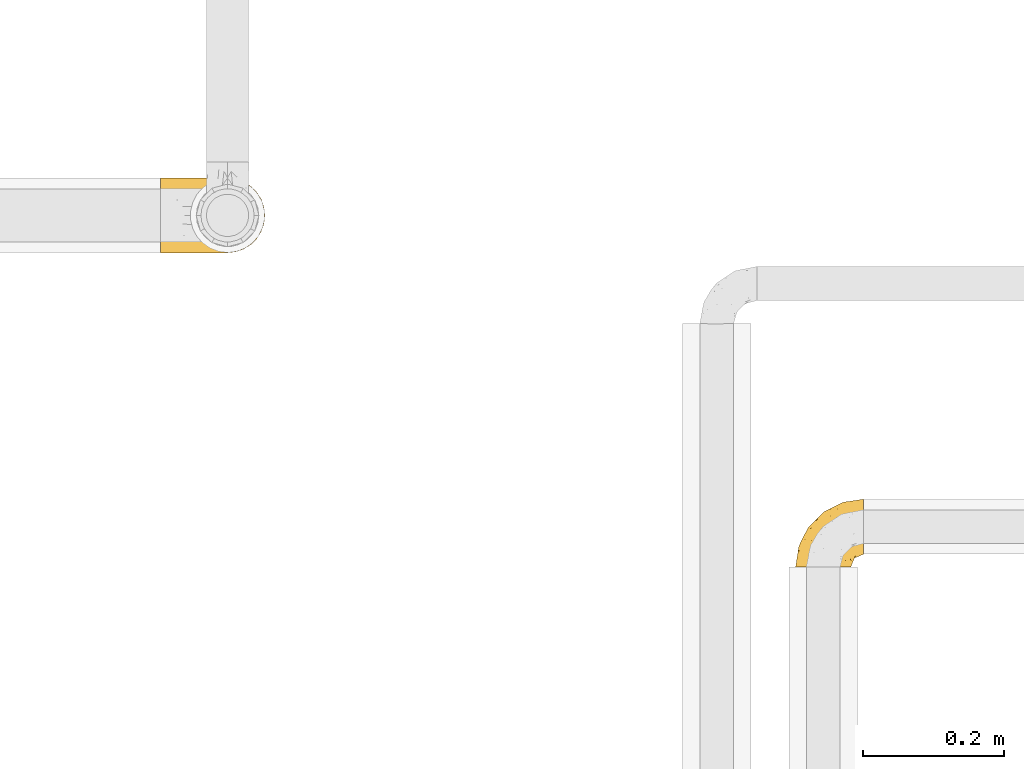
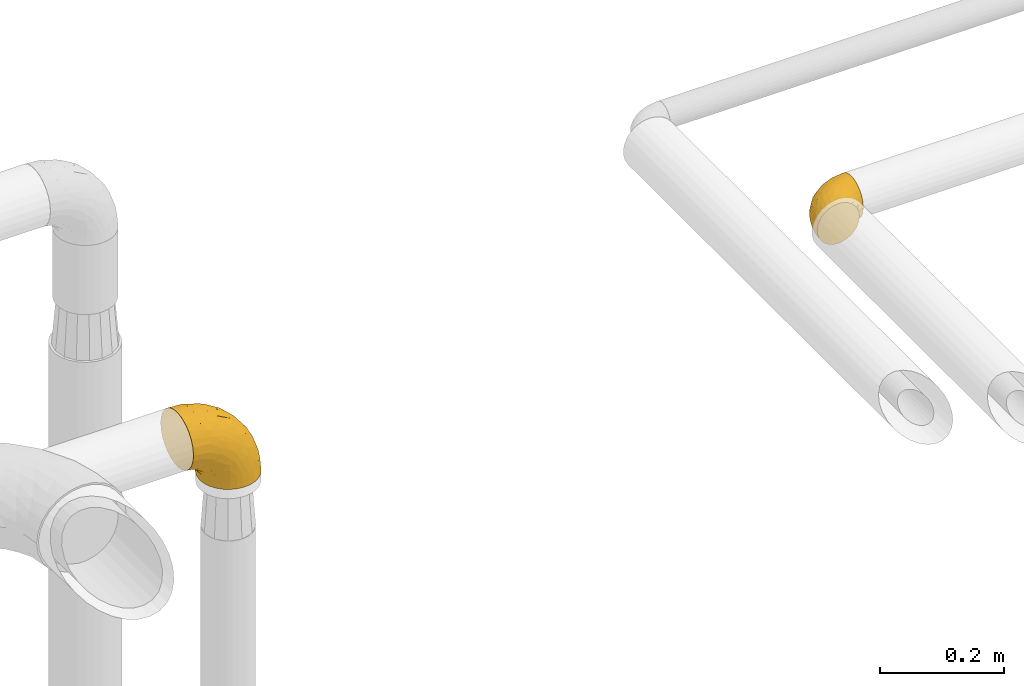
# One storey, part 137 of 827: 2 coverings.
"""IFC2X3 building model written with IfcOpenShell, lengths in millimetres."""

from ifc_helpers import new_model, entity, si_unit, converted_unit, derived_unit, direction, frame, origin, place, context, subcontext, project, spatial, faceted_brep, element, save


model = new_model("IFC2X3")

# Units and contexts
model_context = context("Model", 3, precision=0.01, world=origin(), true_north=direction((6.12303176911189e-17, 1.0)))
body_context = subcontext(model_context, "Body", "Model", "MODEL_VIEW")
ifc_project = project(units=[si_unit("LENGTHUNIT", "METRE", prefix="MILLI"), si_unit("AREAUNIT", "SQUARE_METRE"), si_unit("VOLUMEUNIT", "CUBIC_METRE"), converted_unit("PLANEANGLEUNIT", "DEGREE", entity("IfcRatioMeasure", 0.0174532925199433), si_unit("PLANEANGLEUNIT", "RADIAN"), dimensions=[0, 0, 0, 0, 0, 0, 0]), si_unit("MASSUNIT", "GRAM", prefix="KILO"), derived_unit("MASSDENSITYUNIT", [(si_unit("MASSUNIT", "GRAM", prefix="KILO"), 1), (si_unit("LENGTHUNIT", "METRE"), -3)]), derived_unit("MOMENTOFINERTIAUNIT", [(si_unit("LENGTHUNIT", "METRE"), 4)]), si_unit("TIMEUNIT", "SECOND"), si_unit("FREQUENCYUNIT", "HERTZ"), si_unit("THERMODYNAMICTEMPERATUREUNIT", "DEGREE_CELSIUS"), derived_unit("THERMALTRANSMITTANCEUNIT", [(si_unit("MASSUNIT", "GRAM", prefix="KILO"), 1), (si_unit("THERMODYNAMICTEMPERATUREUNIT", "KELVIN"), -1), (si_unit("TIMEUNIT", "SECOND"), -3)]), derived_unit("VOLUMETRICFLOWRATEUNIT", [(si_unit("LENGTHUNIT", "METRE"), 3), (si_unit("TIMEUNIT", "SECOND"), -1)]), derived_unit("MASSFLOWRATEUNIT", [(si_unit("MASSUNIT", "GRAM", prefix="KILO"), 1), (si_unit("TIMEUNIT", "SECOND"), -1)]), derived_unit("ROTATIONALFREQUENCYUNIT", [(si_unit("TIMEUNIT", "SECOND"), -1)]), si_unit("ELECTRICCURRENTUNIT", "AMPERE"), si_unit("ELECTRICVOLTAGEUNIT", "VOLT"), si_unit("POWERUNIT", "WATT"), si_unit("FORCEUNIT", "NEWTON", prefix="KILO"), si_unit("ILLUMINANCEUNIT", "LUX"), si_unit("LUMINOUSFLUXUNIT", "LUMEN"), si_unit("LUMINOUSINTENSITYUNIT", "CANDELA"), derived_unit("USERDEFINED", [(si_unit("MASSUNIT", "GRAM", prefix="KILO"), -1), (si_unit("LENGTHUNIT", "METRE"), -2), (si_unit("TIMEUNIT", "SECOND"), 3), (si_unit("LUMINOUSFLUXUNIT", "LUMEN"), 1)]), derived_unit("LINEARVELOCITYUNIT", [(si_unit("LENGTHUNIT", "METRE"), 1), (si_unit("TIMEUNIT", "SECOND"), -1)]), si_unit("PRESSUREUNIT", "PASCAL"), derived_unit("USERDEFINED", [(si_unit("LENGTHUNIT", "METRE"), -2), (si_unit("MASSUNIT", "GRAM", prefix="KILO"), 1), (si_unit("TIMEUNIT", "SECOND"), -2)]), derived_unit("LINEARFORCEUNIT", [(si_unit("MASSUNIT", "GRAM", prefix="KILO"), 1), (si_unit("LENGTHUNIT", "METRE"), 1), (si_unit("TIMEUNIT", "SECOND"), -2), (si_unit("LENGTHUNIT", "METRE"), -1)]), derived_unit("PLANARFORCEUNIT", [(si_unit("MASSUNIT", "GRAM", prefix="KILO"), 1), (si_unit("LENGTHUNIT", "METRE"), 1), (si_unit("TIMEUNIT", "SECOND"), -2), (si_unit("LENGTHUNIT", "METRE"), -2)])], contexts=[model_context])

# Site, building, storey
site_placement = place(None, origin())
site = spatial("IfcSite", under=ifc_project, at=site_placement, CompositionType="ELEMENT")
building_placement = place(site_placement, origin())
building = spatial("IfcBuilding", under=site, at=building_placement, CompositionType="ELEMENT")
storey_placement = place(building_placement, frame((0.0, 0.0, 28200.0)))
storey = spatial("IfcBuildingStorey", under=building, at=storey_placement, Name="08", CompositionType="ELEMENT", Elevation=28200.0)

# Coverings
covering_1_placement = place(storey_placement, frame((23473.64, 14446.95, 2955.74)))
element("IfcCovering", 1, at=covering_1_placement, inside=storey, Name=":ADSK_", ObjectType=":ADSK_", PredefinedType="INSULATION", context=body_context, shape_type="Brep", body=[
    faceted_brep([(31.97, 1.6, 78.9), (23.7, 1.6, 75.99), (16.29, 1.61, 71.31), (10.1, 1.62, 65.1), (5.45, 1.64, 57.68), (2.56, 1.65, 49.4), (1.6, 1.67, 40.69), (2.59, 1.69, 31.97), (5.5, 1.7, 23.7), (10.18, 1.72, 16.29), (16.39, 1.73, 10.1), (23.82, 1.74, 5.45), (32.09, 1.74, 2.56), (40.8, 1.75, 1.6), (44.0, 1.75, 1.96), (49.52, 1.74, 2.59), (53.65, 1.74, 4.05), (57.79, 1.74, 5.5), (65.2, 1.73, 10.18), (71.39, 1.72, 16.39), (76.05, 1.7, 23.82), (78.93, 1.69, 32.09), (79.9, 1.67, 40.8), (78.9, 1.65, 49.52), (75.99, 1.64, 57.79), (71.31, 1.62, 65.2), (65.1, 1.61, 71.39), (57.68, 1.6, 76.05), (49.4, 1.6, 78.93), (43.89, 1.6, 79.54), (40.69, 1.6, 79.9), (97.79, 31.04, 13.2), (97.8, 39.16, 6.99), (97.81, 48.61, 3.1), (97.81, 52.33, 2.62), (97.81, 55.54, 2.2), (97.81, 58.75, 1.79), (97.81, 68.88, 3.14), (97.8, 78.31, 7.07), (97.8, 86.41, 13.31), (97.78, 92.61, 21.43), (97.77, 96.51, 30.88), (97.76, 97.82, 41.01), (97.74, 96.47, 51.14), (97.73, 92.54, 60.58), (97.72, 86.3, 68.67), (97.71, 78.18, 74.88), (97.7, 68.73, 78.77), (97.7, 58.6, 80.09), (97.7, 52.18, 79.23), (97.7, 48.46, 78.73), (97.7, 39.03, 74.8), (97.71, 30.93, 68.57), (97.72, 24.73, 60.45), (97.73, 20.84, 51.0), (97.75, 19.52, 40.86), (97.76, 20.87, 30.73), (97.78, 24.8, 21.3), (30.6, 68.83, 40.86), (19.96, 58.19, 40.82), (31.38, 68.0, 54.11), (41.24, 79.46, 40.9), (68.04, 93.12, 40.96), (73.86, 94.19, 47.71), (78.5, 94.77, 40.98), (51.05, 83.98, 51.69), (61.03, 83.78, 62.05), (74.95, 92.51, 54.66), (80.62, 88.92, 63.59), (35.89, 18.55, 79.27), (55.4, 59.48, 77.17), (78.14, 73.44, 75.98), (58.04, 70.78, 72.77), (78.35, 64.34, 79.1), (74.61, 81.22, 70.32), (14.57, 24.8, 66.71), (20.0, 18.98, 72.71), (24.21, 39.71, 70.26), (43.75, 39.99, 78.88), (45.03, 23.41, 79.94), (48.12, 28.03, 79.96), (51.21, 32.66, 79.97), (54.3, 37.28, 79.98), (57.39, 41.9, 80.0), (40.2, 52.72, 74.54), (6.2, 24.56, 52.46), (61.18, 53.68, 79.46), (62.01, 44.99, 80.01), (66.63, 48.08, 80.02), (71.26, 51.17, 80.03), (75.88, 54.26, 80.05), (13.07, 45.37, 48.98), (14.96, 41.23, 58.82), (8.47, 18.58, 60.42), (4.65, 20.93, 40.73), (36.64, 67.55, 62.14), (22.94, 55.87, 57.61), (41.4, 5.17, 79.9), (42.11, 8.74, 79.91), (43.53, 15.88, 79.93), (25.21, 52.22, 64.2), (31.2, 35.24, 75.81), (26.91, 17.81, 76.66), (37.97, 60.94, 69.03), (50.62, 73.92, 66.88), (54.64, 86.29, 40.93), (6.3, 31.39, 40.75), (83.41, 55.76, 80.06), (86.98, 56.47, 80.07), (90.55, 57.18, 80.07), (13.13, 44.79, 40.79), (91.76, 26.32, 63.98), (87.16, 29.77, 69.27), (87.45, 47.68, 78.81), (89.75, 35.47, 73.12), (88.41, 41.53, 76.62), (81.72, 40.22, 76.95), (79.76, 47.1, 79.19), (73.79, 44.48, 79.22), (91.82, 20.02, 51.39), (86.6, 17.33, 51.13), (85.12, 14.29, 40.83), (91.15, 16.79, 40.85), (80.83, 10.19, 50.0), (78.93, 13.32, 58.61), (71.34, 17.58, 69.93), (76.77, 17.74, 65.28), (74.25, 23.17, 70.84), (48.24, 8.48, 79.28), (49.92, 13.45, 79.15), (92.83, 22.88, 58.0), (77.52, 7.07, 55.99), (62.0, 29.24, 78.14), (70.81, 29.52, 75.48), (65.47, 33.68, 78.26), (80.67, 23.37, 66.73), (77.93, 30.52, 73.25), (66.09, 7.99, 71.12), (56.95, 22.98, 78.39), (64.52, 16.18, 74.0), (56.48, 13.36, 77.3), (51.01, 19.39, 79.31), (81.82, 18.37, 60.4), (82.63, 8.27, 40.82), (72.49, 10.85, 65.78), (67.65, 23.5, 74.59), (86.41, 21.97, 60.73), (82.4, 34.49, 74.08), (75.93, 38.65, 77.42), (70.34, 36.65, 77.94), (92.88, 22.95, 23.72), (89.02, 25.61, 17.68), (41.51, 5.32, 1.6), (42.22, 8.89, 1.61), (43.64, 16.03, 1.63), (80.85, 10.23, 31.64), (78.99, 13.39, 23.05), (77.57, 7.13, 25.63), (72.58, 10.95, 15.85), (83.52, 55.91, 1.76), (90.67, 57.33, 1.77), (94.24, 58.04, 1.78), (87.24, 29.88, 12.46), (82.65, 34.64, 7.69), (89.39, 34.98, 8.99), (80.8, 46.68, 2.78), (81.83, 40.36, 4.8), (74.1, 44.99, 2.49), (75.99, 54.41, 1.75), (87.56, 47.83, 3.0), (51.13, 19.54, 2.28), (48.23, 28.18, 1.66), (57.08, 23.11, 3.24), (74.35, 23.29, 10.83), (80.64, 23.03, 15.28), (77.12, 18.03, 16.51), (91.85, 20.06, 30.32), (79.24, 28.77, 10.08), (86.63, 17.37, 30.56), (66.19, 8.11, 10.47), (71.89, 17.58, 12.13), (56.6, 13.5, 4.29), (64.63, 16.31, 7.63), (62.11, 29.38, 3.52), (50.04, 13.59, 2.41), (45.14, 23.56, 1.64), (70.45, 36.79, 3.77), (76.42, 38.26, 4.58), (67.76, 23.65, 7.06), (70.96, 29.66, 6.22), (89.39, 41.05, 5.53), (82.07, 18.33, 21.67), (51.32, 32.81, 1.67), (86.47, 22.05, 20.97), (65.61, 33.78, 3.45), (62.12, 45.14, 1.71), (57.5, 42.05, 1.7), (54.41, 37.43, 1.68), (71.37, 51.32, 1.74), (66.75, 48.23, 1.72), (61.29, 53.83, 2.29), (74.7, 81.33, 11.57), (78.25, 73.58, 5.89), (58.12, 70.9, 9.03), (38.05, 61.04, 12.68), (40.3, 52.84, 7.14), (24.31, 39.82, 11.32), (25.28, 52.3, 17.44), (43.87, 40.13, 2.77), (78.46, 64.49, 2.74), (73.88, 94.22, 34.23), (74.99, 92.57, 27.29), (55.5, 59.61, 4.58), (31.31, 35.37, 5.78), (80.68, 89.01, 18.35), (61.08, 83.86, 19.82), (31.41, 68.05, 27.61), (36.71, 67.64, 19.59), (36.0, 18.7, 2.27), (6.24, 24.61, 29.01), (14.65, 24.9, 14.79), (13.1, 45.41, 32.59), (20.11, 19.1, 8.78), (51.08, 84.02, 30.15), (23.0, 55.93, 24.03), (15.01, 41.3, 22.74), (8.53, 18.66, 21.03), (50.68, 74.0, 14.91), (27.02, 17.94, 4.85)], [[[0, 1, 2, 3, 4, 5, 6, 7, 8, 9, 10, 11, 12, 13, 14, 15, 16, 17, 18, 19, 20, 21, 22, 23, 24, 25, 26, 27, 28, 29, 30]], [[31, 32, 33, 34, 35, 36, 37, 38, 39, 40, 41, 42, 43, 44, 45, 46, 47, 48, 49, 50, 51, 52, 53, 54, 55, 56, 57]], [[58, 59, 60, 61]], [[62, 63, 64]], [[65, 66, 67]], [[67, 66, 68]], [[69, 0, 30]], [[70, 71, 72]], [[44, 43, 67]], [[47, 71, 73]], [[45, 74, 46]], [[68, 45, 44]], [[75, 76, 77]], [[76, 2, 1]], [[78, 79, 80, 81, 82, 83]], [[48, 47, 73]], [[70, 72, 84]], [[4, 85, 5]], [[86, 83, 87, 88, 89, 90]], [[91, 85, 92]], [[76, 75, 2]], [[71, 46, 74]], [[85, 4, 93]], [[45, 68, 74]], [[4, 3, 93]], [[85, 94, 5]], [[86, 78, 83]], [[60, 95, 65]], [[96, 95, 60]], [[75, 3, 2]], [[69, 30, 97, 98, 99, 79]], [[75, 77, 100]], [[43, 64, 63]], [[101, 102, 69]], [[101, 76, 102]], [[46, 71, 47]], [[95, 103, 104]], [[92, 85, 93]], [[63, 105, 65]], [[92, 75, 100]], [[91, 106, 85]], [[84, 78, 70]], [[67, 68, 44]], [[65, 67, 63]], [[65, 61, 60]], [[3, 75, 93]], [[92, 93, 75]], [[102, 76, 1]], [[77, 76, 101]], [[84, 77, 101]], [[77, 103, 100]], [[72, 71, 74]], [[70, 86, 73]], [[104, 74, 66]], [[84, 72, 103]], [[70, 73, 71]], [[73, 90, 107, 108, 109, 48]], [[79, 78, 69]], [[101, 69, 78]], [[91, 92, 96]], [[91, 59, 110, 106]], [[1, 0, 102]], [[69, 102, 0]], [[94, 85, 106]], [[94, 6, 5]], [[74, 68, 66]], [[43, 42, 64]], [[43, 63, 67]], [[73, 86, 90]], [[78, 86, 70]], [[95, 100, 103]], [[96, 92, 100]], [[104, 103, 72]], [[65, 95, 66]], [[74, 104, 72]], [[66, 95, 104]], [[95, 96, 100]], [[91, 96, 60]], [[77, 84, 103]], [[78, 84, 101]], [[60, 59, 91]], [[105, 63, 62]], [[105, 61, 65]], [[111, 52, 112]], [[107, 90, 113]], [[114, 115, 116]], [[50, 107, 113]], [[117, 118, 116]], [[54, 119, 55]], [[97, 30, 29, 28, 98]], [[113, 115, 51]], [[120, 121, 122]], [[123, 120, 124]], [[125, 126, 127]], [[128, 27, 129]], [[130, 54, 53]], [[24, 23, 131]], [[132, 133, 134]], [[135, 112, 136]], [[137, 26, 25]], [[121, 120, 123]], [[138, 139, 132]], [[129, 140, 141]], [[135, 126, 142]], [[26, 140, 27]], [[26, 137, 140]], [[49, 48, 109, 108, 107, 50]], [[22, 143, 121, 123]], [[24, 131, 144]], [[25, 24, 144]], [[128, 98, 28]], [[125, 127, 145]], [[146, 130, 111]], [[137, 144, 139]], [[139, 138, 140]], [[116, 147, 114]], [[123, 124, 131]], [[116, 118, 148]], [[134, 83, 82]], [[129, 79, 99]], [[54, 130, 119]], [[141, 79, 129]], [[122, 55, 119]], [[120, 146, 142]], [[117, 113, 90]], [[50, 113, 51]], [[127, 133, 145]], [[147, 136, 112]], [[136, 133, 127]], [[23, 22, 123]], [[118, 117, 89]], [[149, 87, 134]], [[144, 131, 124]], [[23, 123, 131]], [[128, 129, 99]], [[27, 140, 129]], [[144, 137, 25]], [[140, 137, 139]], [[81, 138, 132]], [[138, 80, 141]], [[89, 88, 87, 118]], [[115, 117, 116]], [[140, 138, 141]], [[148, 118, 149]], [[136, 148, 149]], [[147, 116, 148]], [[133, 136, 149]], [[127, 126, 135]], [[136, 147, 148]], [[114, 112, 52]], [[112, 114, 147]], [[51, 114, 52]], [[51, 115, 114]], [[117, 115, 113]], [[117, 90, 89]], [[134, 133, 149]], [[145, 133, 132]], [[132, 139, 145]], [[125, 139, 144]], [[139, 125, 145]], [[126, 144, 124]], [[144, 126, 125]], [[142, 126, 124]], [[120, 142, 124]], [[142, 146, 135]], [[112, 135, 146]], [[136, 127, 135]], [[118, 87, 149]], [[82, 81, 132]], [[111, 130, 53]], [[119, 146, 120]], [[146, 119, 130]], [[122, 119, 120]], [[52, 111, 53]], [[146, 111, 112]], [[134, 82, 132]], [[83, 134, 87]], [[98, 128, 99]], [[80, 138, 81]], [[80, 79, 141]], [[27, 128, 28]], [[150, 151, 57]], [[14, 13, 152, 153, 154, 15]], [[121, 143, 22, 155]], [[150, 57, 56]], [[156, 157, 158]], [[35, 34, 33, 159, 160, 161, 36]], [[162, 31, 57]], [[163, 164, 162]], [[165, 166, 167]], [[155, 22, 21]], [[168, 159, 169]], [[170, 171, 172]], [[173, 174, 175]], [[55, 122, 176]], [[177, 174, 173]], [[21, 157, 155]], [[178, 121, 155]], [[169, 33, 32]], [[19, 18, 179]], [[20, 19, 158]], [[158, 180, 175]], [[181, 182, 179]], [[172, 183, 182]], [[122, 121, 178]], [[181, 18, 17]], [[184, 185, 170]], [[16, 154, 184]], [[186, 187, 177]], [[187, 186, 167]], [[179, 158, 19]], [[20, 157, 21]], [[175, 180, 173]], [[188, 189, 173]], [[164, 166, 190]], [[185, 184, 154]], [[181, 172, 182]], [[156, 191, 178]], [[192, 183, 172]], [[178, 176, 122]], [[193, 150, 176]], [[33, 169, 159]], [[190, 169, 32]], [[189, 194, 186]], [[180, 188, 173]], [[167, 166, 187]], [[166, 164, 163]], [[195, 194, 196]], [[158, 157, 20]], [[155, 157, 156]], [[178, 155, 156]], [[181, 17, 184]], [[16, 15, 154]], [[181, 179, 18]], [[158, 179, 182]], [[170, 181, 184]], [[196, 194, 197]], [[31, 190, 32]], [[165, 190, 166]], [[190, 31, 164]], [[31, 162, 164]], [[177, 163, 162]], [[187, 166, 163]], [[151, 174, 177]], [[177, 173, 189]], [[177, 187, 163]], [[195, 167, 186]], [[165, 198, 168]], [[165, 168, 169]], [[167, 198, 165]], [[190, 165, 169]], [[167, 195, 199, 198]], [[151, 177, 162]], [[175, 191, 156]], [[191, 174, 193]], [[158, 175, 156]], [[174, 191, 175]], [[178, 191, 193]], [[158, 182, 180]], [[188, 182, 183]], [[182, 188, 180]], [[183, 194, 189]], [[183, 189, 188]], [[177, 189, 186]], [[194, 183, 197]], [[176, 150, 56]], [[151, 150, 193]], [[176, 56, 55]], [[193, 176, 178]], [[174, 151, 193]], [[57, 151, 162]], [[183, 192, 197]], [[194, 195, 186]], [[171, 192, 172]], [[172, 181, 170]], [[170, 185, 171]], [[184, 17, 16]], [[200, 168, 198, 199, 195, 196]], [[201, 202, 203]], [[204, 203, 205]], [[204, 206, 207]], [[208, 196, 197, 192, 171, 185]], [[209, 36, 161, 160, 159, 168]], [[202, 38, 37]], [[201, 38, 202]], [[210, 41, 211]], [[200, 208, 212]], [[205, 208, 213]], [[214, 211, 40]], [[40, 211, 41]], [[214, 201, 215]], [[58, 61, 216, 59]], [[201, 39, 38]], [[207, 217, 204]], [[213, 208, 218]], [[218, 185, 154, 153, 152, 13]], [[13, 12, 218]], [[8, 7, 219]], [[9, 220, 10]], [[221, 106, 110, 59]], [[219, 7, 94]], [[220, 222, 10]], [[223, 211, 215]], [[221, 216, 224]], [[225, 219, 221]], [[9, 8, 226]], [[213, 222, 206]], [[226, 8, 219]], [[106, 219, 94]], [[212, 202, 209]], [[201, 203, 227]], [[226, 225, 220]], [[207, 206, 220]], [[214, 40, 39]], [[10, 222, 11]], [[11, 222, 228]], [[41, 210, 64]], [[223, 105, 210]], [[223, 215, 217]], [[105, 62, 210]], [[206, 222, 220]], [[228, 222, 213]], [[207, 220, 225]], [[205, 206, 204]], [[225, 226, 219]], [[220, 9, 226]], [[209, 202, 37]], [[203, 202, 212]], [[205, 203, 212]], [[204, 217, 227]], [[36, 209, 37]], [[209, 168, 200]], [[218, 12, 228]], [[208, 185, 218]], [[106, 221, 219]], [[221, 59, 216]], [[218, 228, 213]], [[12, 11, 228]], [[7, 6, 94]], [[201, 214, 39]], [[211, 214, 215]], [[64, 210, 62]], [[64, 42, 41]], [[223, 210, 211]], [[208, 200, 196]], [[209, 200, 212]], [[225, 224, 207]], [[207, 224, 217]], [[223, 217, 216]], [[204, 227, 203]], [[217, 215, 227]], [[201, 227, 215]], [[221, 224, 225]], [[217, 224, 216]], [[208, 205, 212]], [[206, 205, 213]], [[216, 61, 223]], [[223, 61, 105]]]),
])
covering_2_placement = place(storey_placement, frame((22572.86, 14892.6, 2503.4)))
element("IfcCovering", 2, at=covering_2_placement, inside=storey, Name=":ADSK_", ObjectType=":ADSK_", PredefinedType="INSULATION", context=body_context, shape_type="Brep", body=[
    faceted_brep([(148.32, 66.44, 1.6), (149.65, 54.65, 1.6), (148.31, 42.84, 1.6), (144.39, 31.62, 1.6), (138.06, 21.56, 1.6), (129.66, 13.16, 1.6), (119.6, 6.84, 1.6), (108.39, 2.92, 1.6), (96.6, 1.6, 1.6), (84.79, 2.93, 1.6), (73.57, 6.85, 1.6), (63.51, 13.18, 1.6), (55.11, 21.58, 1.6), (48.79, 31.64, 1.6), (44.87, 42.85, 1.6), (43.55, 54.65, 1.6), (44.88, 66.46, 1.6), (48.8, 77.67, 1.6), (55.13, 87.73, 1.6), (63.53, 96.13, 1.6), (73.59, 102.45, 1.6), (84.8, 106.37, 1.6), (96.6, 107.7, 1.6), (108.41, 106.36, 1.6), (119.62, 102.44, 1.6), (129.68, 96.11, 1.6), (138.08, 87.71, 1.6), (144.4, 77.65, 1.6), (1.6, 40.91, 45.35), (1.6, 28.12, 50.65), (1.6, 17.13, 59.08), (1.6, 8.7, 70.07), (1.6, 3.4, 82.86), (1.6, 1.6, 96.6), (1.6, 3.4, 110.33), (1.6, 8.7, 123.12), (1.6, 17.13, 134.11), (1.6, 28.12, 142.54), (1.6, 40.91, 147.84), (1.6, 54.65, 149.65), (1.6, 68.38, 147.84), (1.6, 81.17, 142.54), (1.6, 92.16, 134.11), (1.6, 100.59, 123.12), (1.6, 105.89, 110.33), (1.6, 107.7, 96.6), (1.6, 105.89, 82.86), (1.6, 100.59, 70.07), (1.6, 92.16, 59.08), (1.6, 81.17, 50.65), (1.6, 68.38, 45.35), (1.6, 54.65, 43.55), (27.97, 85.53, 137.19), (37.09, 73.42, 141.79), (58.27, 83.77, 128.89), (27.13, 64.22, 146.54), (39.91, 54.65, 144.6), (109.11, 96.72, 69.77), (94.41, 93.36, 94.41), (110.94, 84.47, 87.22), (89.69, 71.37, 117.2), (75.62, 54.65, 129.81), (106.28, 54.65, 106.28), (60.12, 103.47, 101.45), (41.41, 100.91, 115.81), (63.22, 99.1, 109.14), (32.05, 105.43, 107.65), (52.13, 106.79, 93.36), (123.27, 89.81, 59.44), (129.32, 79.59, 63.23), (138.3, 81.29, 35.59), (62.95, 74.01, 132.3), (55.89, 64.14, 138.41), (37.4, 94.75, 126.28), (144.6, 54.65, 39.91), (142.66, 70.74, 37.44), (117.85, 68.3, 90.35), (134.01, 66.05, 65.0), (89.25, 100.73, 85.4), (103.34, 106.78, 26.66), (113.52, 103.6, 29.88), (57.43, 107.7, 78.45), (44.19, 107.7, 85.2), (30.95, 107.7, 91.95), (77.98, 106.07, 77.98), (132.66, 90.59, 29.55), (121.52, 97.43, 41.42), (86.93, 84.51, 111.13), (68.4, 93.3, 114.67), (78.45, 107.7, 57.43), (67.94, 107.7, 67.94), (94.53, 107.7, 14.64), (91.95, 107.7, 30.95), (93.36, 106.79, 52.13), (85.2, 107.7, 44.19), (101.45, 103.47, 60.12), (129.81, 54.65, 75.62), (16.27, 107.7, 94.27), (42.46, 76.99, 24.59), (40.4, 84.28, 34.69), (49.71, 91.11, 31.15), (39.4, 106.26, 75.18), (31.26, 102.6, 67.55), (27.7, 106.08, 79.36), (16.7, 106.56, 84.32), (70.67, 105.36, 40.81), (81.69, 106.74, 29.93), (16.68, 101.59, 70.24), (22.57, 54.65, 37.93), (14.26, 54.65, 40.15), (17.68, 67.71, 42.1), (19.58, 91.36, 55.38), (33.49, 94.33, 52.17), (33.01, 87.1, 44.32), (40.69, 65.84, 19.85), (40.15, 54.65, 14.26), (37.93, 54.65, 22.57), (31.04, 68.92, 34.17), (45.29, 100.82, 54.85), (23.55, 79.83, 44.63), (11.36, 77.13, 47.52), (59.1, 105.9, 59.1), (57.42, 101.53, 44.11), (68.96, 106.72, 53.21), (20.38, 97.75, 62.86), (72.46, 103.08, 20.58), (83.66, 106.39, 15.79), (60.66, 98.1, 27.67), (61.01, 95.02, 13.49), (51.85, 86.9, 18.04), (46.07, 74.42, 12.44), (30.25, 54.65, 30.25), (46.65, 105.28, 66.71), (43.0, 92.87, 42.52), (19.58, 17.93, 55.38), (72.44, 6.22, 20.57), (17.67, 41.58, 42.11), (78.45, 1.6, 57.43), (68.97, 2.57, 53.22), (70.65, 3.94, 40.81), (40.69, 43.46, 19.85), (42.45, 32.32, 24.58), (31.04, 40.38, 34.16), (42.99, 16.44, 42.5), (45.18, 8.47, 54.93), (33.46, 15.01, 52.13), (60.64, 11.21, 27.66), (57.37, 7.78, 44.12), (57.43, 1.6, 78.45), (44.19, 1.6, 85.2), (39.35, 3.04, 75.17), (16.27, 1.6, 94.27), (16.7, 2.73, 84.32), (91.95, 1.6, 30.95), (85.2, 1.6, 44.19), (81.68, 2.55, 29.98), (46.68, 3.98, 66.78), (31.26, 6.69, 67.55), (16.68, 7.7, 70.24), (27.7, 3.21, 79.36), (60.99, 14.28, 13.48), (51.84, 22.42, 18.03), (40.41, 25.02, 34.66), (49.72, 18.18, 31.14), (46.06, 34.89, 12.43), (94.53, 1.6, 14.64), (11.35, 32.17, 47.52), (33.02, 22.23, 44.28), (83.65, 2.91, 15.8), (20.38, 11.54, 62.86), (67.94, 1.6, 67.94), (23.53, 29.46, 44.64), (59.12, 3.38, 59.12), (30.95, 1.6, 91.95), (58.27, 25.52, 128.89), (27.97, 23.76, 137.19), (37.4, 14.54, 126.28), (41.41, 8.38, 115.81), (27.21, 45.07, 146.53), (37.09, 35.87, 141.79), (53.2, 45.14, 139.45), (52.13, 2.5, 93.36), (103.34, 2.51, 26.67), (113.5, 5.68, 29.87), (101.45, 5.82, 60.12), (94.41, 15.93, 94.41), (109.08, 12.54, 69.76), (110.95, 24.81, 87.19), (93.36, 2.5, 52.13), (77.98, 3.22, 77.98), (32.05, 3.86, 107.65), (64.63, 35.85, 131.74), (123.25, 19.47, 59.44), (132.65, 18.68, 29.54), (129.32, 29.68, 63.2), (139.96, 27.95, 27.9), (117.85, 40.99, 90.35), (89.69, 37.92, 117.2), (121.51, 11.85, 41.39), (63.23, 10.19, 109.14), (89.17, 8.55, 85.46), (142.66, 38.53, 37.43), (68.4, 15.99, 114.67), (86.94, 24.79, 111.12), (60.12, 5.82, 101.45), (133.2, 40.56, 65.16)], [[[0, 1, 2, 3, 4, 5, 6, 7, 8, 9, 10, 11, 12, 13, 14, 15, 16, 17, 18, 19, 20, 21, 22, 23, 24, 25, 26, 27]], [[28, 29, 30, 31, 32, 33, 34, 35, 36, 37, 38, 39, 40, 41, 42, 43, 44, 45, 46, 47, 48, 49, 50, 51]], [[52, 53, 54]], [[55, 39, 56]], [[57, 58, 59]], [[60, 61, 62]], [[63, 64, 65]], [[66, 63, 67]], [[68, 69, 70]], [[53, 71, 54]], [[41, 40, 53]], [[53, 72, 71]], [[73, 42, 52]], [[42, 41, 52]], [[74, 0, 75]], [[69, 76, 77]], [[43, 73, 64]], [[45, 44, 66]], [[57, 78, 58]], [[23, 79, 80]], [[67, 81, 82, 83]], [[67, 84, 81]], [[24, 23, 80]], [[25, 85, 26]], [[86, 85, 25]], [[42, 73, 43]], [[0, 27, 75]], [[25, 24, 86]], [[70, 26, 85]], [[0, 74, 1]], [[68, 85, 86]], [[66, 64, 63]], [[60, 59, 87]], [[54, 87, 88]], [[76, 60, 62]], [[84, 89, 90, 81]], [[79, 22, 91, 92]], [[77, 74, 75]], [[93, 92, 94, 89]], [[80, 86, 24]], [[40, 55, 53]], [[76, 59, 60]], [[93, 84, 95]], [[76, 62, 96]], [[55, 72, 53]], [[70, 27, 26]], [[75, 70, 69]], [[78, 84, 63]], [[93, 79, 92]], [[95, 86, 80]], [[77, 76, 96]], [[59, 69, 68]], [[57, 68, 86]], [[68, 57, 59]], [[59, 58, 87]], [[76, 69, 59]], [[88, 87, 58]], [[87, 54, 71]], [[86, 95, 57]], [[78, 57, 95]], [[84, 78, 95]], [[78, 63, 65]], [[58, 78, 65]], [[54, 88, 73]], [[84, 93, 89]], [[79, 95, 80]], [[79, 93, 95]], [[22, 79, 23]], [[66, 83, 97, 45]], [[84, 67, 63]], [[83, 66, 67]], [[64, 44, 43]], [[64, 66, 44]], [[65, 73, 88]], [[53, 52, 41]], [[73, 52, 54]], [[73, 65, 64]], [[65, 88, 58]], [[39, 55, 40]], [[72, 55, 56]], [[56, 61, 72]], [[60, 72, 61]], [[72, 60, 71]], [[87, 71, 60]], [[27, 70, 75]], [[68, 70, 85]], [[74, 77, 96]], [[69, 77, 75]], [[98, 99, 100]], [[46, 45, 97]], [[101, 102, 103]], [[103, 104, 83]], [[105, 94, 106]], [[107, 103, 102]], [[108, 109, 51, 110]], [[111, 112, 113]], [[114, 115, 116]], [[47, 104, 107]], [[110, 117, 108]], [[49, 48, 111]], [[102, 118, 112]], [[119, 120, 111]], [[50, 49, 120]], [[121, 122, 118]], [[105, 123, 89]], [[124, 48, 107]], [[20, 19, 125]], [[121, 81, 90]], [[117, 119, 99]], [[21, 20, 126]], [[22, 21, 91]], [[105, 125, 127]], [[110, 51, 50]], [[19, 128, 125]], [[16, 15, 115]], [[129, 98, 100]], [[126, 91, 21]], [[128, 129, 127]], [[122, 123, 105]], [[114, 117, 98]], [[17, 16, 130]], [[18, 128, 19]], [[129, 18, 17]], [[125, 106, 126]], [[115, 114, 16]], [[130, 129, 17]], [[114, 98, 130]], [[117, 116, 131, 108]], [[99, 119, 113]], [[122, 121, 123]], [[92, 126, 106]], [[105, 127, 122]], [[132, 121, 118]], [[114, 130, 16]], [[129, 130, 98]], [[50, 120, 110]], [[129, 128, 18]], [[125, 128, 127]], [[125, 126, 20]], [[91, 126, 92]], [[105, 89, 94]], [[105, 106, 125]], [[94, 92, 106]], [[100, 122, 127]], [[118, 122, 133]], [[112, 118, 133]], [[132, 118, 102]], [[132, 102, 101]], [[81, 121, 132]], [[82, 103, 83]], [[132, 101, 81]], [[104, 47, 46]], [[124, 107, 102]], [[48, 47, 107]], [[113, 112, 133]], [[112, 111, 124]], [[99, 113, 133]], [[111, 113, 119]], [[99, 133, 100]], [[117, 99, 98]], [[122, 100, 133]], [[127, 129, 100]], [[103, 82, 101]], [[81, 101, 82]], [[112, 124, 102]], [[48, 124, 111]], [[104, 103, 107]], [[46, 97, 104]], [[111, 120, 49]], [[83, 104, 97]], [[110, 120, 119]], [[117, 110, 119]], [[116, 117, 114]], [[89, 123, 90]], [[90, 123, 121]], [[30, 29, 134]], [[11, 10, 135]], [[51, 109, 108, 136]], [[137, 138, 139]], [[140, 141, 142]], [[143, 144, 145]], [[146, 139, 147]], [[148, 149, 150]], [[151, 32, 152]], [[153, 154, 155]], [[156, 150, 157]], [[158, 157, 159]], [[108, 142, 136]], [[31, 158, 152]], [[160, 161, 12]], [[162, 163, 143]], [[140, 142, 116]], [[142, 141, 162]], [[14, 164, 140]], [[14, 140, 115]], [[9, 8, 165]], [[160, 12, 11]], [[141, 164, 161]], [[13, 12, 161]], [[14, 115, 15]], [[28, 166, 29]], [[135, 139, 146]], [[141, 163, 162]], [[135, 146, 160]], [[143, 167, 162]], [[29, 166, 134]], [[116, 142, 108, 131]], [[165, 153, 168]], [[10, 9, 168]], [[168, 135, 10]], [[138, 147, 139]], [[158, 169, 157]], [[14, 13, 164]], [[116, 115, 140]], [[145, 167, 143]], [[135, 160, 11]], [[168, 153, 155]], [[138, 137, 170]], [[157, 144, 156]], [[147, 144, 143]], [[161, 164, 13]], [[140, 164, 141]], [[142, 171, 136]], [[136, 171, 166]], [[161, 160, 146]], [[165, 168, 9]], [[155, 139, 135]], [[139, 154, 137]], [[168, 155, 135]], [[139, 155, 154]], [[144, 147, 172]], [[163, 147, 143]], [[156, 144, 172]], [[157, 169, 145]], [[172, 148, 156]], [[173, 159, 149]], [[159, 157, 150]], [[152, 159, 173]], [[159, 152, 158]], [[31, 30, 158]], [[169, 30, 134]], [[157, 145, 144]], [[167, 134, 171]], [[134, 167, 145]], [[171, 142, 162]], [[162, 167, 171]], [[163, 141, 161]], [[161, 146, 163]], [[147, 163, 146]], [[148, 150, 156]], [[149, 159, 150]], [[30, 169, 158]], [[145, 169, 134]], [[151, 33, 32]], [[31, 152, 32]], [[152, 173, 151]], [[28, 51, 136]], [[134, 166, 171]], [[28, 136, 166]], [[138, 170, 172]], [[147, 138, 172]], [[148, 172, 170]], [[174, 175, 176]], [[35, 34, 177]], [[178, 179, 180]], [[181, 173, 149, 148]], [[182, 183, 184]], [[185, 186, 187]], [[188, 189, 137]], [[190, 33, 151, 173]], [[191, 179, 174]], [[34, 190, 177]], [[39, 38, 178]], [[192, 193, 194]], [[4, 3, 195]], [[175, 179, 37]], [[38, 37, 179]], [[35, 176, 36]], [[196, 62, 197]], [[181, 190, 173]], [[37, 36, 175]], [[183, 6, 198]], [[189, 148, 170, 137]], [[185, 199, 200]], [[3, 2, 201]], [[202, 185, 203]], [[8, 7, 182]], [[200, 184, 186]], [[183, 7, 6]], [[181, 189, 204]], [[200, 189, 184]], [[5, 198, 6]], [[187, 203, 185]], [[195, 3, 201]], [[205, 196, 194]], [[62, 61, 197]], [[186, 198, 192]], [[180, 179, 191]], [[2, 1, 74]], [[198, 193, 192]], [[193, 5, 4]], [[194, 193, 195]], [[2, 74, 201]], [[5, 193, 198]], [[205, 74, 96]], [[188, 137, 154, 153]], [[62, 196, 96]], [[56, 178, 180]], [[198, 184, 183]], [[184, 188, 182]], [[203, 197, 191]], [[205, 194, 201]], [[187, 192, 194]], [[192, 187, 186]], [[194, 196, 187]], [[197, 187, 196]], [[197, 203, 187]], [[202, 174, 176]], [[200, 186, 185]], [[184, 198, 186]], [[199, 185, 202]], [[189, 200, 204]], [[174, 202, 203]], [[176, 177, 199]], [[189, 181, 148]], [[190, 181, 204]], [[190, 204, 177]], [[190, 34, 33]], [[188, 153, 182]], [[189, 188, 184]], [[182, 153, 165, 8]], [[183, 182, 7]], [[199, 177, 204]], [[35, 177, 176]], [[176, 175, 36]], [[179, 175, 174]], [[200, 199, 204]], [[176, 199, 202]], [[203, 191, 174]], [[180, 197, 61]], [[197, 180, 191]], [[61, 56, 180]], [[39, 178, 56]], [[38, 179, 178]], [[194, 195, 201]], [[4, 195, 193]], [[74, 205, 201]], [[96, 196, 205]]]),
])

save(model, "model.ifc")
